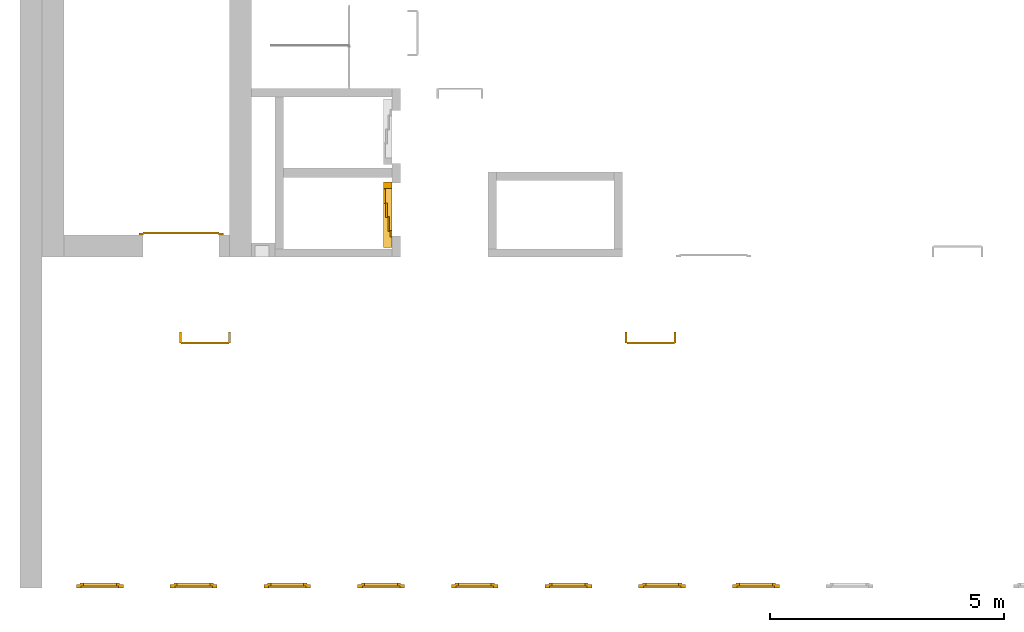
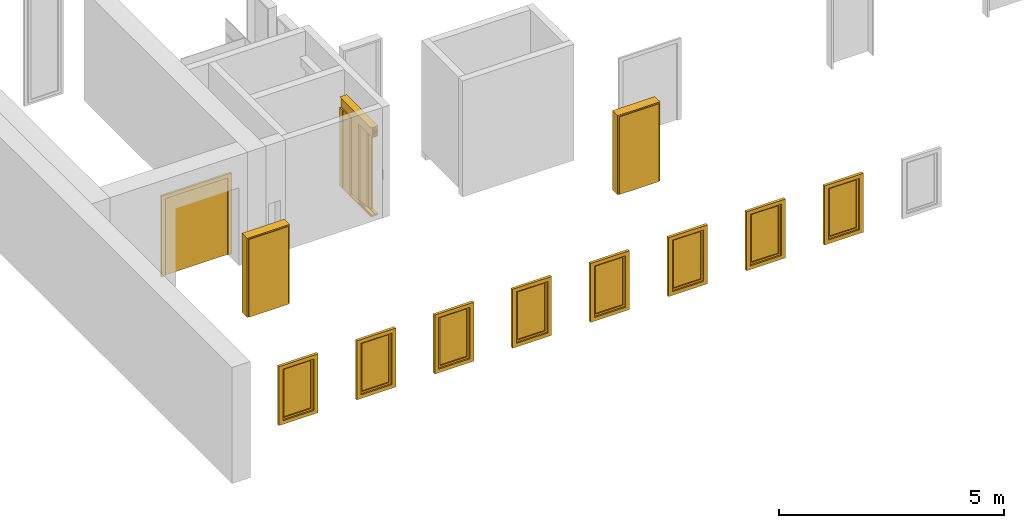
# One storey, part 2 of 5: 8 windows, 4 doors.
"""IFC4 building model written with IfcOpenShell, lengths in metres."""

import ifcopenshell
import ifcopenshell.guid

model = None  # the IFC model being written
_history = None  # IfcOwnerHistory: only IFC2X3 demands one
_inside = {}  # id of a spatial element -> (the spatial element, [elements in it])
_under = {}  # id of a project, library or spatial element -> (it, [spatial elements below it])
_declared = {}  # id of a project -> (the project, [libraries it declares])
_typed = {}  # id of a type object -> (the type object, [elements of that type])
_made_of = {}  # id of a material, layer set ... -> (it, [elements and type objects made of it])


def new_model(schema):
    """Start an empty IFC model of exactly this schema.

    Asked for "IFC4X3", IfcOpenShell would pick the latest addendum, in which some entities
    have other attributes; the version numbers below select the first issue.
    IFC2X3 requires an IfcOwnerHistory on every rooted entity: one is made here for all.
    """
    global model, _history
    if schema == "IFC4X3":
        model = ifcopenshell.file(schema_version=(4, 3, 0, 0))
    else:
        model = ifcopenshell.file(schema=schema)
    _inside.clear()
    _under.clear()
    _declared.clear()
    _typed.clear()
    _made_of.clear()
    _history = None
    if model.schema == "IFC2X3":
        org = make("IfcOrganization", Name="unknown")
        user = make(
            "IfcPersonAndOrganization",
            ThePerson=make("IfcPerson", FamilyName="unknown"),
            TheOrganization=org,
        )
        app = make(
            "IfcApplication",
            ApplicationDeveloper=org,
            Version="unknown",
            ApplicationFullName="unknown",
            ApplicationIdentifier="unknown",
        )
        _history = make(
            "IfcOwnerHistory",
            OwningUser=user,
            OwningApplication=app,
            ChangeAction="ADDED",
            CreationDate=0,
        )
    return model


def make(cls, **values):
    """One entity of the class cls with the attributes given. An attribute that is None is left unset."""
    return model.create_entity(
        cls, **{name: value for name, value in values.items() if value is not None}
    )


def entity(cls, *values):
    """Any entity or typed value of the class cls, its attributes in the order of the schema. None: left unset."""
    e = model.create_entity(cls)
    for i, value in enumerate(values):
        if value is not None:
            e[i] = value
    return e


def rooted(cls, **values):
    """An entity with a GlobalId (a new one), such as an element, a storey or a relation."""
    return make(cls, GlobalId=ifcopenshell.guid.new(), OwnerHistory=_history, **values)


def si_unit(unit_type, name, prefix=None):
    """IfcSIUnit, for example si_unit("LENGTHUNIT", "METRE", prefix="MILLI")."""
    return make("IfcSIUnit", UnitType=unit_type, Prefix=prefix, Name=name)


def converted_unit(unit_type, name, factor, base, dimensions=None, offset=None):
    """IfcConversionBasedUnit, such as the inch: factor (a typed value) times the base unit."""
    return make(
        "IfcConversionBasedUnit"
        if offset is None
        else "IfcConversionBasedUnitWithOffset",
        ConversionOffset=offset,
        Dimensions=None
        if dimensions is None
        else entity("IfcDimensionalExponents", *dimensions),
        UnitType=unit_type,
        Name=name,
        ConversionFactor=make(
            "IfcMeasureWithUnit", ValueComponent=factor, UnitComponent=base
        ),
    )


def derived_unit(unit_type, elements):
    """IfcDerivedUnit: a product of units, each with its exponent."""
    return make(
        "IfcDerivedUnit",
        Elements=[
            make("IfcDerivedUnitElement", Unit=unit, Exponent=power)
            for unit, power in elements
        ],
        UnitType=unit_type,
    )


def assignment(units):
    """IfcUnitAssignment: the units of a project."""
    return None if units is None else make("IfcUnitAssignment", Units=units)


def point(xyz):
    """IfcCartesianPoint."""
    return None if xyz is None else make("IfcCartesianPoint", Coordinates=xyz)


def direction(xyz):
    """IfcDirection."""
    return None if xyz is None else make("IfcDirection", DirectionRatios=xyz)


def frame(location, z_axis=None, x_axis=None):
    """IfcAxis2Placement3D, a coordinate frame: its origin and axes. An axis left out is left unset."""
    return make(
        "IfcAxis2Placement3D",
        Location=point(location),
        Axis=direction(z_axis),
        RefDirection=direction(x_axis),
    )


def origin_with_axes():
    """The frame at (0, 0, 0) with the z axis (0, 0, 1) and the x axis (1, 0, 0) written out."""
    return frame((0.0, 0.0, 0.0), z_axis=(0.0, 0.0, 1.0), x_axis=(1.0, 0.0, 0.0))


def place(relative_to, where):
    """IfcLocalPlacement: puts the frame where relative to a parent placement (None: the world)."""
    return make(
        "IfcLocalPlacement", PlacementRelTo=relative_to, RelativePlacement=where
    )


def context(
    kind, dimensions, precision=None, world=None, true_north=None, identifier=None
):
    """IfcGeometricRepresentationContext, for example the 3D "Model" context."""
    return make(
        "IfcGeometricRepresentationContext",
        ContextIdentifier=identifier,
        ContextType=kind,
        CoordinateSpaceDimension=dimensions,
        Precision=precision,
        WorldCoordinateSystem=world,
        TrueNorth=true_north,
    )


def subcontext(parent, identifier, kind, view, scale=None):
    """IfcGeometricRepresentationSubContext, for example "Body" below "Model"."""
    return make(
        "IfcGeometricRepresentationSubContext",
        ContextIdentifier=identifier,
        ContextType=kind,
        ParentContext=parent,
        TargetScale=scale,
        TargetView=view,
    )


def project(units=None, contexts=None):
    """IfcProject with its units and contexts."""
    return rooted(
        "IfcProject",
        Name="project",
        RepresentationContexts=contexts,
        UnitsInContext=assignment(units),
    )


def spatial(cls, under=None, at=None, **own):
    """A site, building, storey or space (cls), placed at a placement, below another one or the project."""
    s = rooted(cls, ObjectPlacement=at, **own)
    if under is not None:
        _under.setdefault(under.id(), (under, []))[1].append(s)
    return s


def point_list(points):
    """IfcCartesianPointList2D or 3D."""
    cls = (
        "IfcCartesianPointList2D" if len(points[0]) == 2 else "IfcCartesianPointList3D"
    )
    return make(cls, CoordList=points)


def polygons(points, faces, closed=None, point_numbers=None):
    """IfcPolygonalFaceSet: a face is its outer loop, then its inner loops; points numbered from 1."""
    made = []
    for loops in faces:
        if len(loops) == 1:
            made.append(make("IfcIndexedPolygonalFace", CoordIndex=loops[0]))
        else:
            made.append(
                make(
                    "IfcIndexedPolygonalFaceWithVoids",
                    CoordIndex=loops[0],
                    InnerCoordIndices=loops[1:],
                )
            )
    return make(
        "IfcPolygonalFaceSet",
        Coordinates=point_list(points),
        Closed=closed,
        Faces=made,
        PnIndex=point_numbers,
    )


def shape(context_of_items, identifier, shape_type, items):
    """IfcShapeRepresentation: the items that make up one representation, for example the "Body"."""
    return make(
        "IfcShapeRepresentation",
        ContextOfItems=context_of_items,
        RepresentationIdentifier=identifier,
        RepresentationType=shape_type,
        Items=items,
    )


def source(mapping_origin, context_of_items, identifier, shape_type, items):
    """IfcRepresentationMap: a shape defined once, which mapped items show again and again."""
    return make(
        "IfcRepresentationMap",
        MappingOrigin=mapping_origin,
        MappedRepresentation=shape(context_of_items, identifier, shape_type, items),
    )


def transform(
    local_origin,
    x_axis=None,
    y_axis=None,
    z_axis=None,
    scale=None,
    scale2=None,
    scale3=None,
    uniform=True,
):
    """IfcCartesianTransformationOperator3D, or its non-uniform kind. x_axis, y_axis, z_axis: its Axis1, 2, 3."""
    if uniform:
        return make(
            "IfcCartesianTransformationOperator3D",
            Axis1=direction(x_axis),
            Axis2=direction(y_axis),
            LocalOrigin=point(local_origin),
            Scale=scale,
            Axis3=direction(z_axis),
        )
    return make(
        "IfcCartesianTransformationOperator3DnonUniform",
        Axis1=direction(x_axis),
        Axis2=direction(y_axis),
        LocalOrigin=point(local_origin),
        Scale=scale,
        Axis3=direction(z_axis),
        Scale2=scale2,
        Scale3=scale3,
    )


def mapped(mapping_source, mapping_target):
    """IfcMappedItem: shows the shape of a source again, moved by a transform."""
    return make(
        "IfcMappedItem", MappingSource=mapping_source, MappingTarget=mapping_target
    )


def made_of(thing, what):
    """Note that an element or type object is made of a material, layer set ...; save() writes the relation."""
    if what is not None:
        _made_of.setdefault(what.id(), (what, []))[1].append(thing)
    return thing


def type_object(cls, material=None, **own):
    """A type object (cls), such as IfcWallType, which elements share."""
    return made_of(rooted(cls, **own), material)


def element(
    cls,
    number,
    at=None,
    inside=None,
    cuts=None,
    type_object=None,
    material=None,
    context=None,
    identifier="Body",
    shape_type=None,
    held_by="IfcProductDefinitionShape",
    body=None,
    shapes=None,
    **own,
):
    """One element of the class cls, such as IfcWall. Its Tag is "e" and its number.

    at: its placement. inside: the storey or other place that contains it. cuts: it is an
    opening in that element (IfcRelVoidsElement). A single representation is given by context,
    identifier, shape_type and body (its items); several are given by shapes. held_by: the class
    of the entity that holds the representations. save() writes the other relations.
    """
    e = rooted(cls, Tag="e%d" % number, ObjectPlacement=at, **own)
    if body is not None:
        shapes = [shape(context, identifier, shape_type, body)]
    if shapes is not None:
        e.Representation = make(held_by, Representations=shapes)
    if inside is not None:
        _inside.setdefault(inside.id(), (inside, []))[1].append(e)
    if cuts is not None:
        rooted(
            "IfcRelVoidsElement", RelatingBuildingElement=cuts, RelatedOpeningElement=e
        )
    if type_object is not None:
        _typed.setdefault(type_object.id(), (type_object, []))[1].append(e)
    return made_of(e, material)


def aggregate(whole, parts):
    """IfcRelAggregates: a whole, such as a stair, and the parts it consists of."""
    return rooted("IfcRelAggregates", RelatingObject=whole, RelatedObjects=parts)


def save(model, path):
    """Write the relations noted so far, then the file.

    IfcRelAggregates (storeys below a building ...), IfcRelContainedInSpatialStructure (elements
    in a storey), IfcRelDefinesByType, IfcRelAssociatesMaterial and IfcRelDeclares: one each for
    every whole, place, type object, material and project.
    """
    for whole, parts in _under.values():
        aggregate(whole, parts)
    for where, things in _inside.values():
        rooted(
            "IfcRelContainedInSpatialStructure",
            RelatedElements=things,
            RelatingStructure=where,
        )
    for kind, things in _typed.values():
        rooted("IfcRelDefinesByType", RelatedObjects=things, RelatingType=kind)
    for what, things in _made_of.values():
        rooted("IfcRelAssociatesMaterial", RelatedObjects=things, RelatingMaterial=what)
    for by, libraries in _declared.values():
        rooted("IfcRelDeclares", RelatingContext=by, RelatedDefinitions=libraries)
    model.write(path)


model = new_model("IFC4")

# Units and contexts
model_context = context("Model", 3, precision=1e-05, world=origin_with_axes(), true_north=direction((0.0, 1.0)))
body_context = subcontext(model_context, "Body", "Model", "MODEL_VIEW")
ifc_project = project(units=[si_unit("LENGTHUNIT", "METRE"), si_unit("AREAUNIT", "SQUARE_METRE"), si_unit("VOLUMEUNIT", "CUBIC_METRE"), converted_unit("PLANEANGLEUNIT", "DEGREE", entity("IfcPlaneAngleMeasure", 0.0174532925199433), si_unit("PLANEANGLEUNIT", "RADIAN"), dimensions=[0, 0, 0, 0, 0, 0, 0]), converted_unit("TIMEUNIT", "Year", entity("IfcTimeMeasure", 31557600.0), si_unit("TIMEUNIT", "SECOND"), dimensions=[0, 0, 1, 0, 0, 0, 0]), si_unit("MASSUNIT", "GRAM", prefix="KILO"), si_unit("THERMODYNAMICTEMPERATUREUNIT", "DEGREE_CELSIUS"), si_unit("LUMINOUSINTENSITYUNIT", "LUMEN"), si_unit("ENERGYUNIT", "JOULE", prefix="MEGA"), derived_unit("THERMALCONDUCTANCEUNIT", [(si_unit("POWERUNIT", "WATT"), 1), (si_unit("LENGTHUNIT", "METRE"), -1), (si_unit("THERMODYNAMICTEMPERATUREUNIT", "KELVIN"), -1)]), derived_unit("SPECIFICHEATCAPACITYUNIT", [(si_unit("ENERGYUNIT", "JOULE"), 1), (si_unit("MASSUNIT", "GRAM", prefix="KILO"), -1), (si_unit("THERMODYNAMICTEMPERATUREUNIT", "KELVIN"), -1)]), derived_unit("MASSDENSITYUNIT", [(si_unit("MASSUNIT", "GRAM", prefix="KILO"), 1), (si_unit("VOLUMEUNIT", "CUBIC_METRE"), -1)])], contexts=[model_context])

# Site, building, storey
site_placement = place(None, origin_with_axes())
site = spatial("IfcSite", under=ifc_project, at=site_placement, CompositionType="ELEMENT")
building_placement = place(None, origin_with_axes())
building = spatial("IfcBuilding", under=site, at=building_placement, CompositionType="ELEMENT")
storey_placement = place(None, frame((0.0, 0.0, 4.5), z_axis=(0.0, 0.0, 1.0), x_axis=(1.0, 0.0, 0.0)))
storey = spatial("IfcBuildingStorey", under=building, at=storey_placement, Name="1 OG", CompositionType="ELEMENT", Elevation=4.5)

# Windows
window_type = type_object("IfcWindowType", Name="1-27", PartitioningType="SINGLE_PANEL", PredefinedType="WINDOW")
shared_shape_1 = source(origin_with_axes(), body_context, "Body", "Tessellation", [
    polygons([(-0.5, -0.07, 0.0), (-0.5, 0.0, 0.0), (-0.4, 0.0, 0.1), (-0.4, -0.07, 0.1), (-0.5, -0.07, 1.6), (-0.5, 0.0, 1.6), (-0.4, 0.0, 1.5), (-0.4, -0.07, 1.5)], [[[1, 2, 3, 4]], [[5, 6, 2, 1]], [[2, 6, 7, 3]], [[4, 3, 7, 8]], [[1, 4, 8, 5]], [[8, 7, 6, 5]]], closed=True),
    polygons([(0.5, -0.07, 0.0), (0.5, 0.0, 0.0), (0.5, 0.0, 1.6), (0.5, -0.07, 1.6), (0.4, -0.07, 0.1), (0.4, 0.0, 0.1), (0.4, 0.0, 1.5), (0.4, -0.07, 1.5)], [[[1, 2, 3, 4]], [[5, 6, 2, 1]], [[2, 6, 7, 3]], [[4, 3, 7, 8]], [[1, 4, 8, 5]], [[8, 7, 6, 5]]], closed=True),
    polygons([(-0.5, -0.07, 0.0), (-0.5, 0.0, 0.0), (0.5, 0.0, 0.0), (0.5, -0.07, 0.0), (-0.4, -0.07, 0.1), (-0.4, 0.0, 0.1), (0.0, 0.0, 0.1), (0.4, 0.0, 0.1), (0.4, -0.07, 0.1), (0.0, -0.07, 0.1)], [[[1, 2, 3, 4]], [[5, 6, 2, 1]], [[2, 6, 7, 8, 3]], [[4, 3, 8, 9]], [[1, 4, 9, 10, 5]], [[10, 7, 6, 5]], [[9, 8, 7, 10]]], closed=True),
    polygons([(-0.5, -0.07, 1.6), (-0.5, 0.0, 1.6), (-0.4, 0.0, 1.5), (-0.4, -0.07, 1.5), (0.5, -0.07, 1.6), (0.5, 0.0, 1.6), (0.4, 0.0, 1.5), (0.0, 0.0, 1.5), (0.0, -0.07, 1.5), (0.4, -0.07, 1.5)], [[[1, 2, 3, 4]], [[5, 6, 2, 1]], [[2, 6, 7, 8, 3]], [[4, 3, 8, 9]], [[1, 4, 9, 10, 5]], [[10, 7, 6, 5]], [[9, 8, 7, 10]]], closed=True),
    polygons([(-0.42, 0.0, 0.08), (-0.42, 0.03, 0.08), (-0.35, 0.03, 0.15), (-0.35, 0.0, 0.15), (-0.42, 0.0, 1.52), (-0.42, 0.03, 1.52), (-0.35, 0.03, 1.45), (-0.35, 0.0, 1.45)], [[[1, 2, 3, 4]], [[5, 6, 2, 1]], [[2, 6, 7, 3]], [[4, 3, 7, 8]], [[1, 4, 8, 5]], [[8, 7, 6, 5]]], closed=True),
    polygons([(0.42, 0.0, 0.08), (0.35, 0.0, 0.15), (0.35, 0.03, 0.15), (0.42, 0.03, 0.08), (0.42, 0.0, 1.52), (0.35, 0.0, 1.45), (0.35, 0.03, 1.45), (0.42, 0.03, 1.52)], [[[1, 2, 3, 4]], [[1, 5, 6, 2]], [[2, 6, 7, 3]], [[4, 3, 7, 8]], [[5, 1, 4, 8]], [[6, 5, 8, 7]]], closed=True),
    polygons([(-0.42, 0.0, 0.08), (-0.42, 0.03, 0.08), (0.42, 0.03, 0.08), (0.42, 0.0, 0.08), (-0.35, 0.0, 0.15), (-0.35, 0.03, 0.15), (0.35, 0.03, 0.15), (0.35, 0.0, 0.15)], [[[1, 2, 3, 4]], [[5, 6, 2, 1]], [[2, 6, 7, 3]], [[4, 3, 7, 8]], [[1, 4, 8, 5]], [[8, 7, 6, 5]]], closed=True),
    polygons([(-0.42, 0.0, 1.52), (0.42, 0.0, 1.52), (0.42, 0.03, 1.52), (-0.42, 0.03, 1.52), (-0.35, 0.0, 1.45), (0.35, 0.0, 1.45), (0.35, 0.03, 1.45), (-0.35, 0.03, 1.45)], [[[1, 2, 3, 4]], [[1, 5, 6, 2]], [[2, 6, 7, 3]], [[4, 3, 7, 8]], [[5, 1, 4, 8]], [[6, 5, 8, 7]]], closed=True),
    polygons([(-0.4, -0.03, 0.1), (-0.4, 0.0, 0.1), (-0.35, 0.0, 0.15), (-0.35, -0.03, 0.15), (-0.4, -0.03, 1.5), (-0.4, 0.0, 1.5), (-0.35, 0.0, 1.45), (-0.35, -0.03, 1.45)], [[[1, 2, 3, 4]], [[5, 6, 2, 1]], [[2, 6, 7, 3]], [[4, 3, 7, 8]], [[1, 4, 8, 5]], [[8, 7, 6, 5]]], closed=True),
    polygons([(0.4, -0.03, 0.1), (0.35, -0.03, 0.15), (0.35, 0.0, 0.15), (0.4, 0.0, 0.1), (0.4, -0.03, 1.5), (0.35, -0.03, 1.45), (0.35, 0.0, 1.45), (0.4, 0.0, 1.5)], [[[1, 2, 3, 4]], [[1, 5, 6, 2]], [[2, 6, 7, 3]], [[4, 3, 7, 8]], [[5, 1, 4, 8]], [[6, 5, 8, 7]]], closed=True),
    polygons([(-0.4, -0.03, 0.1), (-0.4, 0.0, 0.1), (0.4, 0.0, 0.1), (0.4, -0.03, 0.1), (-0.35, -0.03, 0.15), (-0.35, 0.0, 0.15), (0.35, 0.0, 0.15), (0.35, -0.03, 0.15)], [[[1, 2, 3, 4]], [[5, 6, 2, 1]], [[2, 6, 7, 3]], [[4, 3, 7, 8]], [[1, 4, 8, 5]], [[8, 7, 6, 5]]], closed=True),
    polygons([(-0.4, -0.03, 1.5), (0.4, -0.03, 1.5), (0.4, 0.0, 1.5), (-0.4, 0.0, 1.5), (-0.35, -0.03, 1.45), (0.35, -0.03, 1.45), (0.35, 0.0, 1.45), (-0.35, 0.0, 1.45)], [[[1, 2, 3, 4]], [[1, 5, 6, 2]], [[2, 6, 7, 3]], [[4, 3, 7, 8]], [[5, 1, 4, 8]], [[6, 5, 8, 7]]], closed=True),
    polygons([(-0.35, -0.00500000000000001, 0.15), (-0.35, 0.00499999999999999, 0.15), (0.35, 0.00499999999999999, 0.15), (0.35, -0.00500000000000001, 0.15), (-0.35, -0.00500000000000001, 1.45), (-0.35, 0.00499999999999999, 1.45), (0.35, 0.00499999999999999, 1.45), (0.35, -0.00500000000000001, 1.45)], [[[1, 2, 3, 4]], [[5, 6, 2, 1]], [[2, 6, 7, 3]], [[4, 3, 7, 8]], [[1, 4, 8, 5]], [[8, 7, 6, 5]]], closed=True),
])
window_1_placement = place(None, frame((30.723, 0.0, 5.5), z_axis=(0.0, 0.0, 1.0), x_axis=(1.0, 0.0, 0.0)))
element("IfcWindow", 1, at=window_1_placement, inside=storey, type_object=window_type, Name="Fenster-001", OverallHeight=1.6, OverallWidth=1.0, context=body_context, shape_type="MappedRepresentation", body=[
    mapped(shared_shape_1, transform((0.5, 0.0700000000000025, 0.0))),
])
window_2_placement = place(None, frame((34.723, 0.0, 5.5), z_axis=(0.0, 0.0, 1.0), x_axis=(1.0, 0.0, 0.0)))
element("IfcWindow", 2, at=window_2_placement, inside=storey, type_object=window_type, Name="Fenster-001", OverallHeight=1.6, OverallWidth=1.0, context=body_context, shape_type="MappedRepresentation", body=[
    mapped(shared_shape_1, transform((0.5, 0.0700000000000021, 0.0))),
])
window_3_placement = place(None, frame((32.723, 0.0, 5.5), z_axis=(0.0, 0.0, 1.0), x_axis=(1.0, 0.0, 0.0)))
element("IfcWindow", 3, at=window_3_placement, inside=storey, type_object=window_type, Name="Fenster-001", OverallHeight=1.6, OverallWidth=1.0, context=body_context, shape_type="MappedRepresentation", body=[
    mapped(shared_shape_1, transform((0.5, 0.0700000000000023, 0.0))),
])
window_4_placement = place(None, frame((28.723, 0.0, 5.5), z_axis=(0.0, 0.0, 1.0), x_axis=(1.0, 0.0, 0.0)))
element("IfcWindow", 4, at=window_4_placement, inside=storey, type_object=window_type, Name="Fenster-001", OverallHeight=1.6, OverallWidth=1.0, context=body_context, shape_type="MappedRepresentation", body=[
    mapped(shared_shape_1, transform((0.5, 0.0700000000000028, 0.0))),
])
window_5_placement = place(None, frame((36.723, 0.0, 5.5), z_axis=(0.0, 0.0, 1.0), x_axis=(1.0, 0.0, 0.0)))
element("IfcWindow", 5, at=window_5_placement, inside=storey, type_object=window_type, Name="Fenster-001", OverallHeight=1.6, OverallWidth=1.0, context=body_context, shape_type="MappedRepresentation", body=[
    mapped(shared_shape_1, transform((0.5, 0.0700000000000018, 0.0))),
])
window_6_placement = place(None, frame((24.723, 0.0, 5.5), z_axis=(0.0, 0.0, 1.0), x_axis=(1.0, 0.0, 0.0)))
element("IfcWindow", 6, at=window_6_placement, inside=storey, type_object=window_type, Name="Fenster-001", OverallHeight=1.6, OverallWidth=1.0, context=body_context, shape_type="MappedRepresentation", body=[
    mapped(shared_shape_1, transform((0.5, 0.0700000000000033, 0.0))),
])
window_7_placement = place(None, frame((26.723, 0.0, 5.5), z_axis=(0.0, 0.0, 1.0), x_axis=(1.0, 0.0, 0.0)))
element("IfcWindow", 7, at=window_7_placement, inside=storey, type_object=window_type, Name="Fenster-001", OverallHeight=1.6, OverallWidth=1.0, context=body_context, shape_type="MappedRepresentation", body=[
    mapped(shared_shape_1, transform((0.5, 0.0700000000000031, 0.0))),
])
window_8_placement = place(None, frame((38.723, 0.0, 5.5), z_axis=(0.0, 0.0, 1.0), x_axis=(1.0, 0.0, 0.0)))
element("IfcWindow", 8, at=window_8_placement, inside=storey, type_object=window_type, Name="Fenster-001", OverallHeight=1.6, OverallWidth=1.0, context=body_context, shape_type="MappedRepresentation", body=[
    mapped(shared_shape_1, transform((0.5, 0.0700000000000016, 0.0))),
])

# Doors
door_type_1 = type_object("IfcDoorType", Name="27", OperationType="SINGLE_SWING_RIGHT", PredefinedType="DOOR")
shared_shape_2 = source(origin_with_axes(), body_context, "Body", "Tessellation", [
    polygons([(0.545, -0.2325, 0.0), (0.545, -0.025, 0.0), (0.545, -0.025, 2.145), (0.545, -0.2325, 2.145), (0.5, -0.2325, 0.0), (0.5, -0.025, 0.0), (0.5, -0.025, 2.1), (0.0551, -0.025, 2.1), (0.0001, -0.025, 2.1), (-0.5, -0.025, 2.1), (-0.5, -0.025, 0.0), (-0.545, -0.025, 0.0), (-0.545, -0.025, 2.145), (-0.545, -0.2325, 2.145), (-0.545, -0.2325, 0.0), (-0.5, -0.2325, 0.0), (-0.5, -0.2325, 2.1), (0.0001, -0.2325, 2.1), (0.0551, -0.2325, 2.1), (0.5, -0.2325, 2.1)], [[[1, 2, 3, 4]], [[5, 6, 2, 1]], [[2, 6, 7, 8, 9, 10, 11, 12, 13, 3]], [[4, 3, 13, 14]], [[1, 4, 14, 15, 16, 17, 18, 19, 20, 5]], [[20, 7, 6, 5]], [[19, 8, 7, 20]], [[18, 9, 8, 19]], [[17, 10, 9, 18]], [[16, 11, 10, 17]], [[15, 12, 11, 16]], [[14, 13, 12, 15]]], closed=True),
    polygons([(0.545, -0.025, 0.0), (0.545, 0.0, 0.0), (0.545, 0.0, 2.145), (0.545, -0.025, 2.145), (0.51, -0.025, 0.0), (0.51, 0.0, 0.0), (0.51, 0.0, 2.11), (0.0451, 0.0, 2.11), (0.0101, 0.0, 2.11), (-0.51, 0.0, 2.11), (-0.51, 0.0, 0.0), (-0.545, 0.0, 0.0), (-0.545, 0.0, 2.145), (-0.545, -0.025, 2.145), (-0.545, -0.025, 0.0), (-0.51, -0.025, 0.0), (-0.51, -0.025, 2.11), (0.0101, -0.025, 2.11), (0.0451, -0.025, 2.11), (0.51, -0.025, 2.11)], [[[1, 2, 3, 4]], [[5, 6, 2, 1]], [[2, 6, 7, 8, 9, 10, 11, 12, 13, 3]], [[4, 3, 13, 14]], [[1, 4, 14, 15, 16, 17, 18, 19, 20, 5]], [[20, 7, 6, 5]], [[19, 8, 7, 20]], [[18, 9, 8, 19]], [[17, 10, 9, 18]], [[16, 11, 10, 17]], [[15, 12, 11, 16]], [[14, 13, 12, 15]]], closed=True),
    polygons([(0.51, 0.015, 0.0), (-0.51, 0.015, 0.0), (-0.51, 0.015, 2.11), (0.51, 0.015, 2.11), (0.51, -0.025, 0.0), (-0.51, -0.025, 0.0), (-0.51, -0.025, 2.11), (0.51, -0.025, 2.11)], [[[1, 2, 3, 4]], [[2, 1, 5, 6]], [[3, 2, 6, 7]], [[4, 3, 7, 8]], [[1, 4, 8, 5]], [[6, 5, 8, 7]]], closed=True),
])
door_1_placement = place(None, frame((37.477, 5.45499994546755, 4.5), z_axis=(0.0, 0.0, 1.0), x_axis=(-1.0, 0.0, 0.0)))
element("IfcDoor", 9, at=door_1_placement, inside=storey, type_object=door_type_1, OverallHeight=2.145, OverallWidth=1.09, context=body_context, shape_type="MappedRepresentation", body=[
    mapped(shared_shape_2, transform((0.5, 0.2325, 0.0))),
])
door_type_2 = type_object("IfcDoorType", OperationType="DOUBLE_DOOR_SINGLE_SWING", PredefinedType="DOOR")
shared_shape_3 = source(origin_with_axes(), body_context, "Body", "Tessellation", [
    polygons([(0.9, 0.0, 0.0), (0.9, 0.03, 0.0), (0.9, 0.03, 2.2), (0.9, 0.0, 2.2), (0.8, 0.0, 0.0), (0.8, 0.03, 0.0), (0.8, 0.03, 2.1), (0.1101, 0.03, 2.1), (0.0001, 0.03, 2.1), (-0.8, 0.03, 2.1), (-0.8, 0.03, 0.0), (-0.9, 0.03, 0.0), (-0.9, 0.03, 2.2), (-0.9, 0.0, 2.2), (-0.9, 0.0, 0.0), (-0.8, 0.0, 0.0), (-0.8, 0.0, 2.1), (0.0001, 0.0, 2.1), (0.1101, 0.0, 2.1), (0.8, 0.0, 2.1)], [[[1, 2, 3, 4]], [[5, 6, 2, 1]], [[2, 6, 7, 8, 9, 10, 11, 12, 13, 3]], [[4, 3, 13, 14]], [[1, 4, 14, 15, 16, 17, 18, 19, 20, 5]], [[20, 7, 6, 5]], [[19, 8, 7, 20]], [[18, 9, 8, 19]], [[17, 10, 9, 18]], [[16, 11, 10, 17]], [[15, 12, 11, 16]], [[14, 13, 12, 15]]], closed=True),
    polygons([(0.9, 0.03, 0.0), (0.9, 0.05, 0.0), (0.9, 0.05, 2.2), (0.9, 0.03, 2.2), (0.81, 0.03, 0.0), (0.81, 0.05, 0.0), (0.81, 0.05, 2.11), (0.1001, 0.05, 2.11), (0.0101, 0.05, 2.11), (-0.81, 0.05, 2.11), (-0.81, 0.05, 0.0), (-0.9, 0.05, 0.0), (-0.9, 0.05, 2.2), (-0.9, 0.03, 2.2), (-0.9, 0.03, 0.0), (-0.81, 0.03, 0.0), (-0.81, 0.03, 2.11), (0.0101, 0.03, 2.11), (0.1001, 0.03, 2.11), (0.81, 0.03, 2.11)], [[[1, 2, 3, 4]], [[5, 6, 2, 1]], [[2, 6, 7, 8, 9, 10, 11, 12, 13, 3]], [[4, 3, 13, 14]], [[1, 4, 14, 15, 16, 17, 18, 19, 20, 5]], [[20, 7, 6, 5]], [[19, 8, 7, 20]], [[18, 9, 8, 19]], [[17, 10, 9, 18]], [[16, 11, 10, 17]], [[15, 12, 11, 16]], [[14, 13, 12, 15]]], closed=True),
    polygons([(0.81, 0.07, 0.0), (0.000499999999999945, 0.07, 0.0), (0.000499999999999945, 0.07, 2.11), (0.81, 0.07, 2.11), (0.81, 0.03, 0.0), (0.000499999999999945, 0.03, 0.0), (0.000499999999999945, 0.03, 2.11), (0.81, 0.03, 2.11)], [[[1, 2, 3, 4]], [[2, 1, 5, 6]], [[3, 2, 6, 7]], [[4, 3, 7, 8]], [[1, 4, 8, 5]], [[6, 5, 8, 7]]], closed=True),
    polygons([(-0.81, 0.07, 0.0), (-0.81, 0.07, 2.11), (-0.000499999999999945, 0.07, 2.11), (-0.000499999999999945, 0.07, 0.0), (-0.81, 0.03, 0.0), (-0.81, 0.03, 2.11), (-0.000499999999999945, 0.03, 2.11), (-0.000499999999999945, 0.03, 0.0)], [[[1, 2, 3, 4]], [[1, 5, 6, 2]], [[2, 6, 7, 3]], [[3, 7, 8, 4]], [[4, 8, 5, 1]], [[8, 7, 6, 5]]], closed=True),
])
door_2_placement = place(None, frame((26.158, 7.52499994546755, 4.5), z_axis=(0.0, 0.0, 1.0), x_axis=(1.0, 0.0, 0.0)))
element("IfcDoor", 10, at=door_2_placement, inside=storey, type_object=door_type_2, OverallHeight=2.11, OverallWidth=1.62, context=body_context, shape_type="MappedRepresentation", body=[
    mapped(shared_shape_3, transform((0.800000000000001, 0.0, 0.0))),
])
door_type_3 = type_object("IfcDoorType", Name="27", OperationType="SINGLE_SWING_LEFT", PredefinedType="DOOR")
shared_shape_4 = source(origin_with_axes(), body_context, "Body", "Tessellation", [
    polygons([(-0.545, -0.2325, 0.0), (-0.545, -0.2325, 2.145), (-0.545, -0.025, 2.145), (-0.545, -0.025, 0.0), (-0.5, -0.2325, 0.0), (-0.5, -0.2325, 2.1), (-0.0551, -0.2325, 2.1), (-0.0001, -0.2325, 2.1), (0.5, -0.2325, 2.1), (0.5, -0.2325, 0.0), (0.545, -0.2325, 0.0), (0.545, -0.2325, 2.145), (0.545, -0.025, 2.145), (0.545, -0.025, 0.0), (0.5, -0.025, 0.0), (0.5, -0.025, 2.1), (-0.0001, -0.025, 2.1), (-0.0551, -0.025, 2.1), (-0.5, -0.025, 2.1), (-0.5, -0.025, 0.0)], [[[1, 2, 3, 4]], [[1, 5, 6, 7, 8, 9, 10, 11, 12, 2]], [[2, 12, 13, 3]], [[4, 3, 13, 14, 15, 16, 17, 18, 19, 20]], [[5, 1, 4, 20]], [[6, 5, 20, 19]], [[7, 6, 19, 18]], [[8, 7, 18, 17]], [[9, 8, 17, 16]], [[10, 9, 16, 15]], [[11, 10, 15, 14]], [[12, 11, 14, 13]]], closed=True),
    polygons([(-0.545, -0.025, 0.0), (-0.545, -0.025, 2.145), (-0.545, 0.0, 2.145), (-0.545, 0.0, 0.0), (-0.51, -0.025, 0.0), (-0.51, -0.025, 2.11), (-0.0451, -0.025, 2.11), (-0.0101, -0.025, 2.11), (0.51, -0.025, 2.11), (0.51, -0.025, 0.0), (0.545, -0.025, 0.0), (0.545, -0.025, 2.145), (0.545, 0.0, 2.145), (0.545, 0.0, 0.0), (0.51, 0.0, 0.0), (0.51, 0.0, 2.11), (-0.0101, 0.0, 2.11), (-0.0451, 0.0, 2.11), (-0.51, 0.0, 2.11), (-0.51, 0.0, 0.0)], [[[1, 2, 3, 4]], [[1, 5, 6, 7, 8, 9, 10, 11, 12, 2]], [[2, 12, 13, 3]], [[4, 3, 13, 14, 15, 16, 17, 18, 19, 20]], [[5, 1, 4, 20]], [[6, 5, 20, 19]], [[7, 6, 19, 18]], [[8, 7, 18, 17]], [[9, 8, 17, 16]], [[10, 9, 16, 15]], [[11, 10, 15, 14]], [[12, 11, 14, 13]]], closed=True),
    polygons([(-0.51, 0.015, 0.0), (-0.51, 0.015, 2.11), (0.51, 0.015, 2.11), (0.51, 0.015, 0.0), (-0.51, -0.025, 0.0), (-0.51, -0.025, 2.11), (0.51, -0.025, 2.11), (0.51, -0.025, 0.0)], [[[1, 2, 3, 4]], [[1, 5, 6, 2]], [[2, 6, 7, 3]], [[3, 7, 8, 4]], [[4, 8, 5, 1]], [[8, 7, 6, 5]]], closed=True),
])
door_3_placement = place(None, frame((27.969, 5.45499994546755, 4.5), z_axis=(0.0, 0.0, 1.0), x_axis=(-1.0, 0.0, 0.0)))
element("IfcDoor", 11, at=door_3_placement, inside=storey, type_object=door_type_3, OverallHeight=2.145, OverallWidth=1.09, context=body_context, shape_type="MappedRepresentation", body=[
    mapped(shared_shape_4, transform((0.5, 0.232499999999999, 0.0))),
])
door_type_4 = type_object("IfcDoorType", Name="27", OperationType="DOUBLE_DOOR_SLIDING", PredefinedType="DOOR")
shared_shape_5 = source(origin_with_axes(), body_context, "Body", "Tessellation", [
    polygons([(-0.808333333333334, 0.135, 2.1), (-0.808333333333334, 0.135, 2.138), (0.585, 0.135, 2.138), (0.585, 0.135, 2.1), (-0.808333333333334, 0.0, 2.1), (-0.808333333333334, 0.0, 2.38), (-0.808333333333334, 0.18, 2.38), (-0.808333333333334, 0.18, 2.377), (-0.808333333333334, 0.003, 2.377), (-0.808333333333334, 0.003, 2.103), (-0.808333333333334, 0.132, 2.103), (-0.808333333333334, 0.132, 2.138), (0.585, 0.132, 2.138), (0.585, 0.132, 2.103), (0.585, 0.00299999999999992, 2.103), (0.585, 0.00299999999999992, 2.377), (0.585, 0.18, 2.377), (0.585, 0.18, 2.38), (0.585, 0.0, 2.38), (0.585, 0.0, 2.1)], [[[1, 2, 3, 4]], [[1, 5, 6, 7, 8, 9, 10, 11, 12, 2]], [[2, 12, 13, 3]], [[4, 3, 13, 14, 15, 16, 17, 18, 19, 20]], [[5, 1, 4, 20]], [[6, 5, 20, 19]], [[7, 6, 19, 18]], [[8, 7, 18, 17]], [[9, 8, 17, 16]], [[10, 9, 16, 15]], [[11, 10, 15, 14]], [[12, 11, 14, 13]]], closed=True),
    polygons([(-0.808333333333334, 0.05, 2.103), (-0.808333333333334, 0.055, 2.103), (0.585, 0.0549999999999999, 2.103), (0.585, 0.0499999999999999, 2.103), (-0.808333333333334, 0.05, 2.34), (-0.808333333333334, 0.055, 2.34), (0.585, 0.0549999999999999, 2.34), (0.585, 0.0499999999999999, 2.34)], [[[1, 2, 3, 4]], [[1, 5, 6, 2]], [[2, 6, 7, 3]], [[4, 3, 7, 8]], [[5, 1, 4, 8]], [[6, 5, 8, 7]]], closed=True),
    polygons([(-0.808333333333334, 0.05, 2.33), (-0.808333333333334, 0.04, 2.33), (0.585, 0.0399999999999999, 2.33), (0.585, 0.0499999999999999, 2.33), (-0.808333333333334, 0.05, 2.27), (-0.808333333333334, 0.04, 2.27), (0.585, 0.0399999999999999, 2.27), (0.585, 0.0499999999999999, 2.27)], [[[1, 2, 3, 4]], [[1, 5, 6, 2]], [[2, 6, 7, 3]], [[4, 3, 7, 8]], [[5, 1, 4, 8]], [[6, 5, 8, 7]]], closed=True),
    polygons([(-0.808333333333334, 0.05, 2.2), (-0.808333333333334, 0.04, 2.2), (0.585, 0.0399999999999999, 2.2), (0.585, 0.0499999999999999, 2.2), (-0.808333333333334, 0.05, 2.16), (-0.808333333333334, 0.04, 2.16), (0.585, 0.0399999999999999, 2.16), (0.585, 0.0499999999999999, 2.16)], [[[1, 2, 3, 4]], [[1, 5, 6, 2]], [[2, 6, 7, 3]], [[4, 3, 7, 8]], [[5, 1, 4, 8]], [[6, 5, 8, 7]]], closed=True),
    polygons([(-0.808333333333334, 0.05, 2.27), (-0.808333333333334, 0.03, 2.27), (0.585, 0.0299999999999999, 2.27), (0.585, 0.0499999999999999, 2.27), (-0.808333333333334, 0.05, 2.2), (-0.808333333333334, 0.03, 2.2), (0.585, 0.0299999999999999, 2.2), (0.585, 0.0499999999999999, 2.2)], [[[1, 2, 3, 4]], [[1, 5, 6, 2]], [[2, 6, 7, 3]], [[4, 3, 7, 8]], [[5, 1, 4, 8]], [[6, 5, 8, 7]]], closed=True),
    polygons([(-0.808333333333334, 0.095, 2.103), (-0.808333333333334, 0.1, 2.103), (0.585, 0.0999999999999999, 2.103), (0.585, 0.0949999999999999, 2.103), (-0.808333333333334, 0.095, 2.34), (-0.808333333333334, 0.1, 2.34), (0.585, 0.0999999999999999, 2.34), (0.585, 0.0949999999999999, 2.34)], [[[1, 2, 3, 4]], [[1, 5, 6, 2]], [[2, 6, 7, 3]], [[4, 3, 7, 8]], [[5, 1, 4, 8]], [[6, 5, 8, 7]]], closed=True),
    polygons([(-0.808333333333334, 0.095, 2.33), (-0.808333333333334, 0.085, 2.33), (0.585, 0.0849999999999999, 2.33), (0.585, 0.0949999999999999, 2.33), (-0.808333333333334, 0.095, 2.27), (-0.808333333333334, 0.085, 2.27), (0.585, 0.0849999999999999, 2.27), (0.585, 0.0949999999999999, 2.27)], [[[1, 2, 3, 4]], [[1, 5, 6, 2]], [[2, 6, 7, 3]], [[4, 3, 7, 8]], [[5, 1, 4, 8]], [[6, 5, 8, 7]]], closed=True),
    polygons([(-0.808333333333334, 0.095, 2.2), (-0.808333333333334, 0.085, 2.2), (0.585, 0.0849999999999999, 2.2), (0.585, 0.0949999999999999, 2.2), (-0.808333333333334, 0.095, 2.16), (-0.808333333333334, 0.085, 2.16), (0.585, 0.0849999999999999, 2.16), (0.585, 0.0949999999999999, 2.16)], [[[1, 2, 3, 4]], [[1, 5, 6, 2]], [[2, 6, 7, 3]], [[4, 3, 7, 8]], [[5, 1, 4, 8]], [[6, 5, 8, 7]]], closed=True),
    polygons([(-0.808333333333334, 0.095, 2.27), (-0.808333333333334, 0.075, 2.27), (0.585, 0.0749999999999999, 2.27), (0.585, 0.0949999999999999, 2.27), (-0.808333333333334, 0.095, 2.2), (-0.808333333333334, 0.075, 2.2), (0.585, 0.0749999999999999, 2.2), (0.585, 0.0949999999999999, 2.2)], [[[1, 2, 3, 4]], [[1, 5, 6, 2]], [[2, 6, 7, 3]], [[4, 3, 7, 8]], [[5, 1, 4, 8]], [[6, 5, 8, 7]]], closed=True),
    polygons([(-0.808333333333334, 0.14, 2.103), (-0.808333333333334, 0.145, 2.103), (0.585, 0.145, 2.103), (0.585, 0.14, 2.103), (-0.808333333333334, 0.14, 2.34), (-0.808333333333334, 0.145, 2.34), (0.585, 0.145, 2.34), (0.585, 0.14, 2.34)], [[[1, 2, 3, 4]], [[1, 5, 6, 2]], [[2, 6, 7, 3]], [[4, 3, 7, 8]], [[5, 1, 4, 8]], [[6, 5, 8, 7]]], closed=True),
    polygons([(-0.808333333333334, 0.14, 2.33), (-0.808333333333334, 0.13, 2.33), (0.585, 0.13, 2.33), (0.585, 0.14, 2.33), (-0.808333333333334, 0.14, 2.27), (-0.808333333333334, 0.13, 2.27), (0.585, 0.13, 2.27), (0.585, 0.14, 2.27)], [[[1, 2, 3, 4]], [[1, 5, 6, 2]], [[2, 6, 7, 3]], [[4, 3, 7, 8]], [[5, 1, 4, 8]], [[6, 5, 8, 7]]], closed=True),
    polygons([(-0.808333333333334, 0.14, 2.2), (-0.808333333333334, 0.13, 2.2), (0.585, 0.13, 2.2), (0.585, 0.14, 2.2), (-0.808333333333334, 0.14, 2.16), (-0.808333333333334, 0.13, 2.16), (0.585, 0.13, 2.16), (0.585, 0.14, 2.16)], [[[1, 2, 3, 4]], [[1, 5, 6, 2]], [[2, 6, 7, 3]], [[4, 3, 7, 8]], [[5, 1, 4, 8]], [[6, 5, 8, 7]]], closed=True),
    polygons([(-0.808333333333334, 0.14, 2.27), (-0.808333333333334, 0.12, 2.27), (0.585, 0.12, 2.27), (0.585, 0.14, 2.27), (-0.808333333333334, 0.14, 2.2), (-0.808333333333334, 0.12, 2.2), (0.585, 0.12, 2.2), (0.585, 0.14, 2.2)], [[[1, 2, 3, 4]], [[1, 5, 6, 2]], [[2, 6, 7, 3]], [[4, 3, 7, 8]], [[5, 1, 4, 8]], [[6, 5, 8, 7]]], closed=True),
    polygons([(-0.808333333333334, 0.0, 0.0), (-0.808333333333334, 0.0, -0.04), (0.585, 0.0, -0.04), (0.585, 0.0, 0.0), (-0.808333333333334, 0.065, 0.0), (-0.808333333333334, 0.065, -0.01), (-0.808333333333334, 0.075, -0.01), (-0.808333333333334, 0.075, 0.0), (-0.808333333333334, 0.11, 0.0), (-0.808333333333334, 0.11, -0.01), (-0.808333333333334, 0.12, -0.01), (-0.808333333333334, 0.12, 0.0), (-0.808333333333334, 0.155, 0.0), (-0.808333333333334, 0.155, -0.01), (-0.808333333333334, 0.165, -0.01), (-0.808333333333334, 0.165, 0.0), (-0.808333333333334, 0.18, 0.0), (-0.808333333333334, 0.18, -0.04), (0.585, 0.18, -0.04), (0.585, 0.18, 0.0), (0.585, 0.165, 0.0), (0.585, 0.165, -0.01), (0.585, 0.155, -0.01), (0.585, 0.155, 0.0), (0.585, 0.12, 0.0), (0.585, 0.12, -0.01), (0.585, 0.11, -0.01), (0.585, 0.11, 0.0), (0.585, 0.0749999999999999, 0.0), (0.585, 0.0749999999999999, -0.01), (0.585, 0.0649999999999999, -0.01), (0.585, 0.0649999999999999, 0.0)], [[[1, 2, 3, 4]], [[1, 5, 6, 7, 8, 9, 10, 11, 12, 13, 14, 15, 16, 17, 18, 2]], [[2, 18, 19, 3]], [[4, 3, 19, 20, 21, 22, 23, 24, 25, 26, 27, 28, 29, 30, 31, 32]], [[5, 1, 4, 32]], [[6, 5, 32, 31]], [[7, 6, 31, 30]], [[8, 7, 30, 29]], [[9, 8, 29, 28]], [[10, 9, 28, 27]], [[11, 10, 27, 26]], [[12, 11, 26, 25]], [[13, 12, 25, 24]], [[14, 13, 24, 23]], [[15, 14, 23, 22]], [[16, 15, 22, 21]], [[17, 16, 21, 20]], [[18, 17, 20, 19]]], closed=True),
    polygons([(-0.45, 0.0, 0.0), (-0.45, 0.045, 0.0), (-0.45, 0.0449999999999999, 2.1), (-0.45, 0.0, 2.1), (-0.585, 0.0, 0.0), (-0.585, 0.045, 0.0), (-0.585, 0.0449999999999999, 2.1), (-0.585, 0.0, 2.1)], [[[1, 2, 3, 4]], [[1, 5, 6, 2]], [[2, 6, 7, 3]], [[4, 3, 7, 8]], [[5, 1, 4, 8]], [[6, 5, 8, 7]]], closed=True),
    polygons([(0.585, 0.0, 0.0), (0.585, 0.18, 0.0), (0.585, 0.18, 2.1), (0.585, 0.0, 2.1), (0.45, 0.0, 0.0), (0.45, 0.18, 0.0), (0.45, 0.18, 2.1), (0.45, 0.0, 2.1)], [[[1, 2, 3, 4]], [[1, 5, 6, 2]], [[2, 6, 7, 3]], [[4, 3, 7, 8]], [[5, 1, 4, 8]], [[6, 5, 8, 7]]], closed=True),
    polygons([(-0.745, -0.18, 0.8), (-0.665, -0.18, 0.8), (-0.665, -0.183, 0.8), (-0.745, -0.183, 0.8), (-0.745, -0.18, 1.06), (-0.665, -0.18, 1.06), (-0.735, -0.18, 1.03), (-0.735, -0.18, 0.94), (-0.675, -0.18, 0.94), (-0.675, -0.18, 1.03), (-0.715, -0.18, 0.84), (-0.695, -0.18, 0.84), (-0.695, -0.18, 0.86), (-0.715, -0.18, 0.86), (-0.715, -0.18, 0.88), (-0.695, -0.18, 0.88), (-0.695, -0.18, 0.9), (-0.715, -0.18, 0.9), (-0.665, -0.183, 1.06), (-0.745, -0.183, 1.06), (-0.735, -0.183, 1.03), (-0.675, -0.183, 1.03), (-0.675, -0.183, 0.94), (-0.735, -0.183, 0.94), (-0.715, -0.183, 0.84), (-0.715, -0.183, 0.86), (-0.695, -0.183, 0.86), (-0.695, -0.183, 0.84), (-0.715, -0.183, 0.88), (-0.715, -0.183, 0.9), (-0.695, -0.183, 0.9), (-0.695, -0.183, 0.88)], [[[1, 2, 3, 4]], [[1, 5, 6, 2], [7, 8, 9, 10], [11, 12, 13, 14], [15, 16, 17, 18]], [[2, 6, 19, 3]], [[4, 3, 19, 20], [21, 22, 23, 24], [25, 26, 27, 28], [29, 30, 31, 32]], [[5, 1, 4, 20]], [[6, 5, 20, 19]], [[8, 7, 21, 24]], [[9, 8, 24, 23]], [[10, 9, 23, 22]], [[7, 10, 22, 21]], [[12, 11, 25, 28]], [[13, 12, 28, 27]], [[14, 13, 27, 26]], [[11, 14, 26, 25]], [[16, 15, 29, 32]], [[17, 16, 32, 31]], [[18, 17, 31, 30]], [[15, 18, 30, 29]]], closed=True),
    polygons([(-0.735, -0.18, 0.94), (-0.675, -0.18, 0.94), (-0.675, -0.1825, 0.94), (-0.735, -0.1825, 0.94), (-0.735, -0.18, 1.03), (-0.675, -0.18, 1.03), (-0.675, -0.1825, 1.03), (-0.735, -0.1825, 1.03)], [[[1, 2, 3, 4]], [[1, 5, 6, 2]], [[2, 6, 7, 3]], [[4, 3, 7, 8]], [[5, 1, 4, 8]], [[6, 5, 8, 7]]], closed=True),
    polygons([(-0.721, -0.183, 1.005), (-0.715, -0.183, 1.021), (-0.709, -0.183, 1.005)], [[[1, 2, 3]]], closed=False),
    polygons([(-0.695, -0.183, 1.005), (-0.701, -0.183, 1.021), (-0.689, -0.183, 1.021)], [[[1, 2, 3]]], closed=False),
    polygons([(-0.707727272727273, -0.1835, 0.982), (-0.707727272727273, -0.1835, 0.971636363636364), (-0.709090909090909, -0.1835, 0.970272727272727), (-0.710454545454546, -0.1835, 0.971636363636364), (-0.710454545454546, -0.1835, 0.982), (-0.709090909090909, -0.1835, 0.983363636363636)], [[[1, 2, 3, 4, 5, 6]]], closed=False),
    polygons([(-0.707727272727273, -0.1835, 0.968363636363636), (-0.707727272727273, -0.1835, 0.958), (-0.709090909090909, -0.1835, 0.956636363636364), (-0.710454545454546, -0.1835, 0.958), (-0.710454545454546, -0.1835, 0.968363636363636), (-0.709090909090909, -0.1835, 0.969727272727273)], [[[1, 2, 3, 4, 5, 6]]], closed=False),
    polygons([(-0.688909090909091, -0.1835, 0.982272727272727), (-0.699272727272727, -0.1835, 0.982272727272727), (-0.700636363636364, -0.1835, 0.983636363636364), (-0.699272727272727, -0.1835, 0.985), (-0.688909090909091, -0.1835, 0.985), (-0.687545454545455, -0.1835, 0.983636363636364)], [[[1, 2, 3, 4, 5, 6]]], closed=False),
    polygons([(-0.685909090909091, -0.1835, 0.982), (-0.685909090909091, -0.1835, 0.971636363636364), (-0.687272727272727, -0.1835, 0.970272727272727), (-0.688636363636364, -0.1835, 0.971636363636364), (-0.688636363636364, -0.1835, 0.982), (-0.687272727272727, -0.1835, 0.983363636363636)], [[[1, 2, 3, 4, 5, 6]]], closed=False),
    polygons([(-0.688909090909091, -0.1835, 0.968636363636364), (-0.699272727272727, -0.1835, 0.968636363636364), (-0.700636363636364, -0.1835, 0.97), (-0.699272727272727, -0.1835, 0.971363636363636), (-0.688909090909091, -0.1835, 0.971363636363636), (-0.687545454545455, -0.1835, 0.97)], [[[1, 2, 3, 4, 5, 6]]], closed=False),
    polygons([(-0.699545454545455, -0.1835, 0.968363636363636), (-0.699545454545455, -0.1835, 0.958), (-0.700909090909091, -0.1835, 0.956636363636364), (-0.702272727272727, -0.1835, 0.958), (-0.702272727272727, -0.1835, 0.968363636363636), (-0.700909090909091, -0.1835, 0.969727272727273)], [[[1, 2, 3, 4, 5, 6]]], closed=False),
    polygons([(-0.688909090909091, -0.1835, 0.955), (-0.699272727272727, -0.1835, 0.955), (-0.700636363636364, -0.1835, 0.956363636363636), (-0.699272727272727, -0.1835, 0.957727272727273), (-0.688909090909091, -0.1835, 0.957727272727273), (-0.687545454545455, -0.1835, 0.956363636363636)], [[[1, 2, 3, 4, 5, 6]]], closed=False),
    polygons([(-0.695, -0.18, 0.84), (-0.715, -0.18, 0.84), (-0.715, -0.18, 0.86), (-0.695, -0.18, 0.86), (-0.694999999905229, -0.1815, 0.839999999610484), (-0.715000000389516, -0.1815, 0.839999999610484), (-0.715000000389516, -0.1815, 0.860000000094772), (-0.694999999905229, -0.1815, 0.860000000094772), (-0.696400000320971, -0.182900000415742, 0.841400000026226), (-0.713599999973774, -0.182900000415742, 0.841400000026226), (-0.713599999973774, -0.182900000415742, 0.858599999679029), (-0.696400000320971, -0.182900000415742, 0.858599999679029)], [[[1, 2, 3, 4]], [[2, 1, 5, 6]], [[3, 2, 6, 7]], [[4, 3, 7, 8]], [[1, 4, 8, 5]], [[6, 5, 9, 10]], [[7, 6, 10, 11]], [[8, 7, 11, 12]], [[5, 8, 12, 9]], [[11, 10, 9, 12]]], closed=True),
    polygons([(-0.7, -0.183, 0.855), (-0.705, -0.183, 0.844), (-0.71, -0.183, 0.855)], [[[1, 2, 3]]], closed=False),
    polygons([(-0.695, -0.18, 0.88), (-0.715, -0.18, 0.88), (-0.715, -0.18, 0.9), (-0.695, -0.18, 0.9), (-0.694999999905229, -0.1815, 0.879999999610484), (-0.715000000389516, -0.1815, 0.879999999610484), (-0.715000000389516, -0.1815, 0.900000000094772), (-0.694999999905229, -0.1815, 0.900000000094772), (-0.696400000320971, -0.182900000415742, 0.881400000026226), (-0.713599999973774, -0.182900000415742, 0.881400000026226), (-0.713599999973774, -0.182900000415742, 0.898599999679029), (-0.696400000320971, -0.182900000415742, 0.898599999679029)], [[[1, 2, 3, 4]], [[2, 1, 5, 6]], [[3, 2, 6, 7]], [[4, 3, 7, 8]], [[1, 4, 8, 5]], [[6, 5, 9, 10]], [[7, 6, 10, 11]], [[8, 7, 11, 12]], [[5, 8, 12, 9]], [[11, 10, 9, 12]]], closed=True),
    polygons([(-0.7, -0.183, 0.885), (-0.71, -0.183, 0.885), (-0.705, -0.183, 0.896)], [[[1, 2, 3]]], closed=False),
    polygons([(0.126666666666667, 0.14, 0.003), (0.126666666666667, 0.18, 0.003), (0.445, 0.18, 0.003), (0.445, 0.14, 0.003), (0.126666666666667, 0.14, 2.1), (0.126666666666667, 0.18, 2.1), (0.445, 0.18, 2.1), (0.445, 0.14, 2.1)], [[[1, 2, 3, 4]], [[5, 6, 2, 1]], [[2, 6, 7, 3]], [[4, 3, 7, 8]], [[1, 4, 8, 5]], [[8, 7, 6, 5]]], closed=True),
    polygons([(-0.171666666666667, 0.095, 0.003), (-0.171666666666667, 0.135, 0.003), (0.146666666666667, 0.135, 0.003), (0.146666666666667, 0.095, 0.003), (-0.171666666666667, 0.095, 2.1), (-0.171666666666667, 0.135, 2.1), (0.146666666666667, 0.135, 2.1), (0.146666666666667, 0.095, 2.1)], [[[1, 2, 3, 4]], [[5, 6, 2, 1]], [[2, 6, 7, 3]], [[4, 3, 7, 8]], [[1, 4, 8, 5]], [[8, 7, 6, 5]]], closed=True),
    polygons([(-0.47, 0.05, 0.003), (-0.47, 0.09, 0.003), (-0.151666666666667, 0.09, 0.003), (-0.151666666666667, 0.05, 0.003), (-0.47, 0.05, 2.1), (-0.47, 0.09, 2.1), (-0.151666666666667, 0.09, 2.1), (-0.151666666666667, 0.05, 2.1)], [[[1, 2, 3, 4]], [[5, 6, 2, 1]], [[2, 6, 7, 3]], [[4, 3, 7, 8]], [[1, 4, 8, 5]], [[8, 7, 6, 5]]], closed=True),
])
door_4_placement = place(None, frame((31.638, 7.61999994546756, 4.5), z_axis=(0.0, 0.0, 1.0), x_axis=(0.0, 1.0, 0.0)))
element("IfcDoor", 12, at=door_4_placement, inside=storey, type_object=door_type_4, OverallHeight=2.25, OverallWidth=1.13, context=body_context, shape_type="MappedRepresentation", body=[
    mapped(shared_shape_5, transform((0.450000000000001, 0.18, 0.0))),
])

save(model, "model.ifc")
